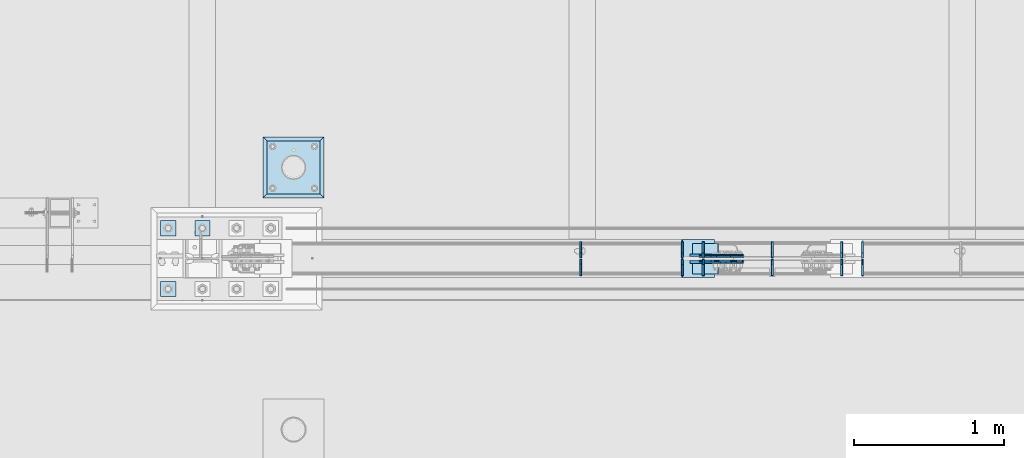
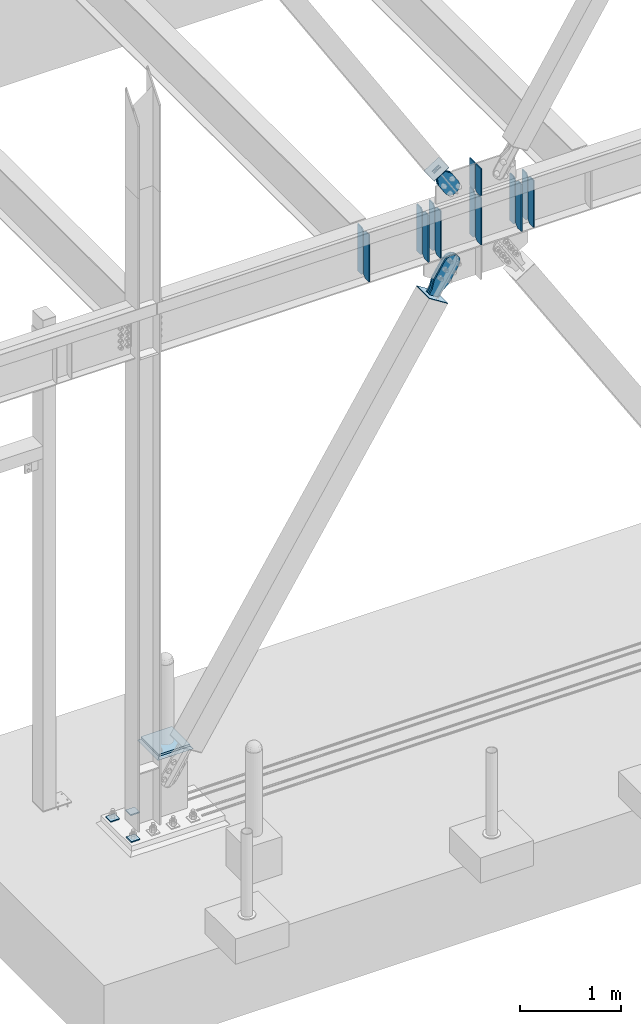
# One storey, part 3383 of 3843: 25 plates, 10 elements without a shape of their own.
"""IFC2X3 building model written with IfcOpenShell, lengths in millimetres."""

from ifc_helpers import new_model, si_unit, frame, origin_with_axes, place, context, subcontext, project, spatial, faceted_brep, material, type_object, element, aggregate, save


model = new_model("IFC2X3")

# Units and contexts
model_context = context("Model", 3, precision=1e-05, world=origin_with_axes())
body_context = subcontext(model_context, "Body", "Model", "MODEL_VIEW")
ifc_project = project(units=[si_unit("LENGTHUNIT", "METRE", prefix="MILLI"), si_unit("AREAUNIT", "SQUARE_METRE"), si_unit("VOLUMEUNIT", "CUBIC_METRE"), si_unit("MASSUNIT", "GRAM", prefix="KILO"), si_unit("TIMEUNIT", "SECOND"), si_unit("PLANEANGLEUNIT", "RADIAN"), si_unit("SOLIDANGLEUNIT", "STERADIAN"), si_unit("THERMODYNAMICTEMPERATUREUNIT", "DEGREE_CELSIUS"), si_unit("LUMINOUSINTENSITYUNIT", "LUMEN")], contexts=[model_context])

# Site, building, storey
site_placement = place(None, origin_with_axes())
site = spatial("IfcSite", under=ifc_project, at=site_placement, CompositionType="ELEMENT")
building_placement = place(site_placement, origin_with_axes())
building = spatial("IfcBuilding", under=site, at=building_placement, Name="Undefined", CompositionType="ELEMENT")
storey_placement = place(building_placement, origin_with_axes())
storey = spatial("IfcBuildingStorey", under=building, at=storey_placement, Name="Undefined", CompositionType="ELEMENT", Elevation=0.0)

# Assembly, plate
assembly_1_placement = place(storey_placement, origin_with_axes())
assembly_1 = element("IfcElementAssembly", 1, at=assembly_1_placement, inside=storey, Name="PIPE_BOLLARD", AssemblyPlace="NOTDEFINED", PredefinedType="RIGID_FRAME")
ifc_material_1 = material(Name="STEEL/A572-50")
plate_type_1 = type_object("IfcPlateType", PredefinedType="NOTDEFINED")
plate_1_placement = place(assembly_1_placement, frame((23291.8, 89547.7, 30518.1), z_axis=(0.0, 1.0, 0.0), x_axis=(1.0, 0.0, 0.0)))
plate_1 = element("IfcPlate", 2, at=plate_1_placement, type_object=plate_type_1, material=ifc_material_1, Name="PLATE", context=body_context, shape_type="Brep", body=[
    faceted_brep([(0.0, -12.6999999999971, 0.0), (0.0, -12.7000000000007, 355.600000000006), (0.0, 12.7000000000007, 355.600000000006), (0.0, 12.6999999999971, 0.0), (355.599999999999, -12.7000000000007, 355.600000000006), (355.599999999999, 12.7000000000007, 355.600000000006), (355.599999999999, -12.7000000000007, 0.0), (355.599999999999, 12.7000000000007, 0.0)], [[[0, 1, 2, 3]], [[1, 4, 5, 2]], [[4, 6, 7, 5]], [[6, 0, 3, 7]], [[5, 7, 3, 2]], [[6, 4, 1, 0]]]),
])
aggregate(assembly_1, [plate_1])

assembly_2_placement = place(storey_placement, origin_with_axes())
assembly_2 = element("IfcElementAssembly", 3, at=assembly_2_placement, inside=storey, Name="GROUT", AssemblyPlace="NOTDEFINED", PredefinedType="REINFORCEMENT_UNIT")
ifc_material_2 = material(Name="CONCRETE/Concrete_Undefined")
plate_type_2 = type_object("IfcPlateType", PredefinedType="NOTDEFINED")
plate_2_placement = place(assembly_2_placement, frame((23266.4, 89522.3, 30492.7), z_axis=(0.0, 1.0, 0.0), x_axis=(1.0, 0.0, 0.0)))
plate_2 = element("IfcPlate", 4, at=plate_2_placement, type_object=plate_type_2, material=ifc_material_2, Name="GROUT", context=body_context, shape_type="Brep", body=[
    faceted_brep([(25.4000000001906, -12.6999999998552, 380.999999999505), (0.0, 12.7000000000007, 406.399999999994), (0.0, 12.6999999999971, 0.0), (25.4000000001906, -12.6999999999898, 25.4000000004453), (380.999999999833, -12.6999999998588, 25.4000000004453), (406.400000000001, 12.7000000000007, 0.0), (406.400000000001, 12.7000000000007, 406.399999999994), (380.999999999833, -12.6999999999898, 380.999999999505)], [[[0, 1, 2, 3]], [[4, 5, 6, 7]], [[4, 7, 0, 3]], [[5, 4, 3, 2]], [[6, 5, 2, 1]], [[7, 6, 1, 0]]]),
])
aggregate(assembly_2, [plate_2])

# Assembly, plates
assembly_3_placement = place(storey_placement, origin_with_axes())
assembly_3 = element("IfcElementAssembly", 5, at=assembly_3_placement, inside=storey, Name="BEAM", AssemblyPlace="NOTDEFINED", PredefinedType="RIGID_FRAME")
plate_type_3 = type_object("IfcPlateType", PredefinedType="NOTDEFINED")
plate_3_placement = place(assembly_3_placement, frame((25388.8874999046, 89110.34375, 35848.925), z_axis=(0.0, 0.0, 1.0), x_axis=(0.0, -1.0, 0.0)))
plate_3 = element("IfcPlate", 6, at=plate_3_placement, type_object=plate_type_3, material=ifc_material_1, Name="PLATE", context=body_context, shape_type="Brep", body=[
    faceted_brep([(0.0, -6.35000000000582, 31.75), (0.0, -6.34999999999854, 539.75), (0.0, 6.34999999999854, 539.75), (0.0, 6.35000000000582, 31.75), (31.75, -6.34999999999854, 571.5), (31.75, 6.34999999999854, 571.5), (108.743750000009, -6.34999999999854, 571.5), (108.743750000009, 6.34999999999854, 571.5), (108.743750000009, -6.34999999999854, 0.0), (108.743750000009, 6.34999999999854, 0.0), (31.75, -6.35000000000582, 0.0), (31.75, 6.35000000000582, 0.0)], [[[0, 1, 2, 3]], [[1, 4, 5, 2]], [[4, 6, 7, 5]], [[6, 8, 9, 7]], [[8, 10, 11, 9]], [[10, 0, 3, 11]], [[5, 7, 9, 11, 3, 2]], [[10, 8, 6, 4, 1, 0]]]),
])
plate_type_4 = type_object("IfcPlateType", PredefinedType="NOTDEFINED")
plate_4_placement = place(assembly_3_placement, frame((25388.8874999046, 89121.45625, 35848.925), z_axis=(0.0, 0.0, 1.0), x_axis=(0.0, 1.0, 0.0)))
plate_4 = element("IfcPlate", 7, at=plate_4_placement, type_object=plate_type_4, material=ifc_material_1, Name="PLATE", context=body_context, shape_type="Brep", body=[
    faceted_brep([(0.0, -6.35000000000582, 31.75), (0.0, -6.34999999999854, 539.75), (0.0, 6.34999999999854, 539.75), (0.0, 6.35000000000582, 31.75), (31.75, -6.34999999999854, 571.5), (31.75, 6.34999999999854, 571.5), (107.950000000012, -6.34999999999854, 571.5), (107.950000000012, 6.34999999999854, 571.5), (107.950000000012, -6.34999999999854, 0.0), (107.950000000012, 6.34999999999854, 0.0), (31.75, -6.35000000000582, 0.0), (31.75, 6.35000000000582, 0.0)], [[[0, 1, 2, 3]], [[1, 4, 5, 2]], [[4, 6, 7, 5]], [[6, 8, 9, 7]], [[8, 10, 11, 9]], [[10, 0, 3, 11]], [[5, 7, 9, 11, 3, 2]], [[10, 8, 6, 4, 1, 0]]]),
])
plate_type_5 = type_object("IfcPlateType", PredefinedType="NOTDEFINED")
plate_5_placement = place(assembly_3_placement, frame((26067.8016625453, 89121.45625, 35848.925), z_axis=(0.0, 1.0, 0.0), x_axis=(0.0, 0.0, 1.0)))
plate_5 = element("IfcPlate", 8, at=plate_5_placement, type_object=plate_type_5, material=ifc_material_1, Name="CB_BEAM", context=body_context, shape_type="Brep", body=[
    faceted_brep([(0.0, -6.34999999999854, 33.3375015258789), (0.0, -6.34999999999854, 108.743749999994), (0.0, 6.34999999999854, 108.743749999994), (0.0, 6.34999999999854, 33.3375015258789), (571.5, -6.34999999999854, 108.743749999994), (571.5, 6.34999999999854, 108.743749999994), (571.5, -6.34999999999854, 33.3375015258789), (571.5, 6.34999999999854, 33.3375015258789), (538.162498474121, -6.34999999999854, 0.0), (538.162498474121, 6.34999999999854, 0.0), (33.3375015258789, -6.34999999999854, 0.0), (33.3375015258789, 6.34999999999854, 0.0)], [[[0, 1, 2, 3]], [[1, 4, 5, 2]], [[4, 6, 7, 5]], [[6, 8, 9, 7]], [[8, 10, 11, 9]], [[10, 0, 3, 11]], [[5, 7, 9, 11, 3, 2]], [[10, 8, 6, 4, 1, 0]]]),
])
plate_6_placement = place(assembly_3_placement, frame((26067.8016625453, 89110.34375, 35848.925), z_axis=(0.0, -1.0, 0.0), x_axis=(0.0, 0.0, 1.0)))
plate_6 = element("IfcPlate", 9, at=plate_6_placement, type_object=plate_type_5, material=ifc_material_1, Name="CB_BEAM", context=body_context, shape_type="Brep", body=[
    faceted_brep([(0.0, -6.34999999999854, 33.3375015258789), (0.0, -6.34999999999854, 108.743749999994), (0.0, 6.34999999999854, 108.743749999994), (0.0, 6.34999999999854, 33.3375015258789), (571.5, -6.34999999999854, 108.743749999994), (571.5, 6.34999999999854, 108.743749999994), (571.5, -6.34999999999854, 33.3375015258789), (571.5, 6.34999999999854, 33.3375015258789), (538.162498474121, -6.34999999999854, 0.0), (538.162498474121, 6.34999999999854, 0.0), (33.3375015258789, -6.34999999999854, 0.0), (33.3375015258789, 6.34999999999854, 0.0)], [[[0, 1, 2, 3]], [[1, 4, 5, 2]], [[4, 6, 7, 5]], [[6, 8, 9, 7]], [[8, 10, 11, 9]], [[10, 0, 3, 11]], [[5, 7, 9, 11, 3, 2]], [[10, 8, 6, 4, 1, 0]]]),
])
plate_7_placement = place(assembly_3_placement, frame((26207.1319682996, 89121.45625, 35848.9250050158), z_axis=(0.0, 1.0, 0.0), x_axis=(0.0, 0.0, 1.0)))
plate_7 = element("IfcPlate", 10, at=plate_7_placement, type_object=plate_type_5, material=ifc_material_1, Name="CB_BEAM", context=body_context, shape_type="Brep", body=[
    faceted_brep([(0.0, -6.34999999999854, 33.3375015258789), (0.0, -6.34999999999854, 108.743749999994), (0.0, 6.34999999999854, 108.743749999994), (0.0, 6.34999999999854, 33.3375015258789), (571.5, -6.34999999999854, 108.743749999994), (571.5, 6.34999999999854, 108.743749999994), (571.5, -6.34999999999854, 33.3375015258789), (571.5, 6.34999999999854, 33.3375015258789), (538.162498474121, -6.34999999999854, 0.0), (538.162498474121, 6.34999999999854, 0.0), (33.3375015258789, -6.34999999999854, 0.0), (33.3375015258789, 6.34999999999854, 0.0)], [[[0, 1, 2, 3]], [[1, 4, 5, 2]], [[4, 6, 7, 5]], [[6, 8, 9, 7]], [[8, 10, 11, 9]], [[10, 0, 3, 11]], [[5, 7, 9, 11, 3, 2]], [[10, 8, 6, 4, 1, 0]]]),
])
plate_8_placement = place(assembly_3_placement, frame((26207.1319682996, 89110.34375, 35848.9250050158), z_axis=(0.0, -1.0, 0.0), x_axis=(0.0, 0.0, 1.0)))
plate_8 = element("IfcPlate", 11, at=plate_8_placement, type_object=plate_type_5, material=ifc_material_1, Name="CB_BEAM", context=body_context, shape_type="Brep", body=[
    faceted_brep([(0.0, -6.34999999999854, 33.3375015258789), (0.0, -6.34999999999854, 108.743749999994), (0.0, 6.34999999999854, 108.743749999994), (0.0, 6.34999999999854, 33.3375015258789), (571.5, -6.34999999999854, 108.743749999994), (571.5, 6.34999999999854, 108.743749999994), (571.5, -6.34999999999854, 33.3375015258789), (571.5, 6.34999999999854, 33.3375015258789), (538.162498474121, -6.34999999999854, 0.0), (538.162498474121, 6.34999999999854, 0.0), (33.3375015258789, -6.34999999999854, 0.0), (33.3375015258789, 6.34999999999854, 0.0)], [[[0, 1, 2, 3]], [[1, 4, 5, 2]], [[4, 6, 7, 5]], [[6, 8, 9, 7]], [[8, 10, 11, 9]], [[10, 0, 3, 11]], [[5, 7, 9, 11, 3, 2]], [[10, 8, 6, 4, 1, 0]]]),
])
plate_9_placement = place(assembly_3_placement, frame((27272.1976786645, 89121.45625, 35848.9250050158), z_axis=(0.0, 1.0, 0.0), x_axis=(0.0, 0.0, 1.0)))
plate_9 = element("IfcPlate", 12, at=plate_9_placement, type_object=plate_type_5, material=ifc_material_1, Name="CB_BEAM", context=body_context, shape_type="Brep", body=[
    faceted_brep([(0.0, -6.34999999999854, 33.3375015258789), (0.0, -6.34999999999854, 108.743749999994), (0.0, 6.34999999999854, 108.743749999994), (0.0, 6.34999999999854, 33.3375015258789), (571.5, -6.34999999999854, 108.743749999994), (571.5, 6.34999999999854, 108.743749999994), (571.5, -6.34999999999854, 33.3375015258789), (571.5, 6.34999999999854, 33.3375015258789), (538.162498474121, -6.34999999999854, 0.0), (538.162498474121, 6.34999999999854, 0.0), (33.3375015258789, -6.34999999999854, 0.0), (33.3375015258789, 6.34999999999854, 0.0)], [[[0, 1, 2, 3]], [[1, 4, 5, 2]], [[4, 6, 7, 5]], [[6, 8, 9, 7]], [[8, 10, 11, 9]], [[10, 0, 3, 11]], [[5, 7, 9, 11, 3, 2]], [[10, 8, 6, 4, 1, 0]]]),
])
plate_10_placement = place(assembly_3_placement, frame((27272.1976786645, 89110.34375, 35848.9250050158), z_axis=(0.0, -1.0, 0.0), x_axis=(0.0, 0.0, 1.0)))
plate_10 = element("IfcPlate", 13, at=plate_10_placement, type_object=plate_type_5, material=ifc_material_1, Name="CB_BEAM", context=body_context, shape_type="Brep", body=[
    faceted_brep([(0.0, -6.34999999999854, 33.3375015258789), (0.0, -6.34999999999854, 108.743749999994), (0.0, 6.34999999999854, 108.743749999994), (0.0, 6.34999999999854, 33.3375015258789), (571.5, -6.34999999999854, 108.743749999994), (571.5, 6.34999999999854, 108.743749999994), (571.5, -6.34999999999854, 33.3375015258789), (571.5, 6.34999999999854, 33.3375015258789), (538.162498474121, -6.34999999999854, 0.0), (538.162498474121, 6.34999999999854, 0.0), (33.3375015258789, -6.34999999999854, 0.0), (33.3375015258789, 6.34999999999854, 0.0)], [[[0, 1, 2, 3]], [[1, 4, 5, 2]], [[4, 6, 7, 5]], [[6, 8, 9, 7]], [[8, 10, 11, 9]], [[10, 0, 3, 11]], [[5, 7, 9, 11, 3, 2]], [[10, 8, 6, 4, 1, 0]]]),
])
plate_11_placement = place(assembly_3_placement, frame((27132.8677160584, 89121.45625, 35848.925), z_axis=(0.0, 1.0, 0.0), x_axis=(0.0, 0.0, 1.0)))
plate_11 = element("IfcPlate", 14, at=plate_11_placement, type_object=plate_type_5, material=ifc_material_1, Name="CB_BEAM", context=body_context, shape_type="Brep", body=[
    faceted_brep([(0.0, -6.34999999999854, 33.3375015258789), (0.0, -6.34999999999854, 108.743749999994), (0.0, 6.34999999999854, 108.743749999994), (0.0, 6.34999999999854, 33.3375015258789), (571.5, -6.34999999999854, 108.743749999994), (571.5, 6.34999999999854, 108.743749999994), (571.5, -6.34999999999854, 33.3375015258789), (571.5, 6.34999999999854, 33.3375015258789), (538.162498474121, -6.34999999999854, 0.0), (538.162498474121, 6.34999999999854, 0.0), (33.3375015258789, -6.34999999999854, 0.0), (33.3375015258789, 6.34999999999854, 0.0)], [[[0, 1, 2, 3]], [[1, 4, 5, 2]], [[4, 6, 7, 5]], [[6, 8, 9, 7]], [[8, 10, 11, 9]], [[10, 0, 3, 11]], [[5, 7, 9, 11, 3, 2]], [[10, 8, 6, 4, 1, 0]]]),
])
plate_12_placement = place(assembly_3_placement, frame((27132.8677160584, 89110.34375, 35848.925), z_axis=(0.0, -1.0, 0.0), x_axis=(0.0, 0.0, 1.0)))
plate_12 = element("IfcPlate", 15, at=plate_12_placement, type_object=plate_type_5, material=ifc_material_1, Name="CB_BEAM", context=body_context, shape_type="Brep", body=[
    faceted_brep([(0.0, -6.34999999999854, 33.3375015258789), (0.0, -6.34999999999854, 108.743749999994), (0.0, 6.34999999999854, 108.743749999994), (0.0, 6.34999999999854, 33.3375015258789), (571.5, -6.34999999999854, 108.743749999994), (571.5, 6.34999999999854, 108.743749999994), (571.5, -6.34999999999854, 33.3375015258789), (571.5, 6.34999999999854, 33.3375015258789), (538.162498474121, -6.34999999999854, 0.0), (538.162498474121, 6.34999999999854, 0.0), (33.3375015258789, -6.34999999999854, 0.0), (33.3375015258789, 6.34999999999854, 0.0)], [[[0, 1, 2, 3]], [[1, 4, 5, 2]], [[4, 6, 7, 5]], [[6, 8, 9, 7]], [[8, 10, 11, 9]], [[10, 0, 3, 11]], [[5, 7, 9, 11, 3, 2]], [[10, 8, 6, 4, 1, 0]]]),
])
plate_13_placement = place(assembly_3_placement, frame((26670.0000031996, 89121.45625, 35848.925), z_axis=(0.0, 1.0, 0.0), x_axis=(0.0, 0.0, 1.0)))
plate_13 = element("IfcPlate", 16, at=plate_13_placement, type_object=plate_type_5, material=ifc_material_1, Name="CB_BEAM", context=body_context, shape_type="Brep", body=[
    faceted_brep([(0.0, -6.34999999999854, 33.3375015258789), (0.0, -6.34999999999854, 108.743749999994), (0.0, 6.34999999999854, 108.743749999994), (0.0, 6.34999999999854, 33.3375015258789), (571.5, -6.34999999999854, 108.743749999994), (571.5, 6.34999999999854, 108.743749999994), (571.5, -6.34999999999854, 33.3375015258789), (571.5, 6.34999999999854, 33.3375015258789), (538.162498474121, -6.34999999999854, 0.0), (538.162498474121, 6.34999999999854, 0.0), (33.3375015258789, -6.34999999999854, 0.0), (33.3375015258789, 6.34999999999854, 0.0)], [[[0, 1, 2, 3]], [[1, 4, 5, 2]], [[4, 6, 7, 5]], [[6, 8, 9, 7]], [[8, 10, 11, 9]], [[10, 0, 3, 11]], [[5, 7, 9, 11, 3, 2]], [[10, 8, 6, 4, 1, 0]]]),
])
plate_14_placement = place(assembly_3_placement, frame((26670.0000031996, 89110.34375, 35848.925), z_axis=(0.0, -1.0, 0.0), x_axis=(0.0, 0.0, 1.0)))
plate_14 = element("IfcPlate", 17, at=plate_14_placement, type_object=plate_type_5, material=ifc_material_1, Name="CB_BEAM", context=body_context, shape_type="Brep", body=[
    faceted_brep([(0.0, -6.34999999999854, 33.3375015258789), (0.0, -6.34999999999854, 108.743749999994), (0.0, 6.34999999999854, 108.743749999994), (0.0, 6.34999999999854, 33.3375015258789), (571.5, -6.34999999999854, 108.743749999994), (571.5, 6.34999999999854, 108.743749999994), (571.5, -6.34999999999854, 33.3375015258789), (571.5, 6.34999999999854, 33.3375015258789), (538.162498474121, -6.34999999999854, 0.0), (538.162498474121, 6.34999999999854, 0.0), (33.3375015258789, -6.34999999999854, 0.0), (33.3375015258789, 6.34999999999854, 0.0)], [[[0, 1, 2, 3]], [[1, 4, 5, 2]], [[4, 6, 7, 5]], [[6, 8, 9, 7]], [[8, 10, 11, 9]], [[10, 0, 3, 11]], [[5, 7, 9, 11, 3, 2]], [[10, 8, 6, 4, 1, 0]]]),
])
plate_type_6 = type_object("IfcPlateType", PredefinedType="NOTDEFINED")
plate_15_placement = place(assembly_3_placement, frame((26670.0000031996, 89125.425, 36436.3), z_axis=(0.0, 1.0, 0.0), x_axis=(0.0, 0.0, 1.0)))
plate_15 = element("IfcPlate", 18, at=plate_15_placement, type_object=plate_type_6, material=ifc_material_1, Name="CB", context=body_context, shape_type="Brep", body=[
    faceted_brep([(0.0, -6.34999999999854, 19.0499992370605), (0.0, -6.34999999999854, 104.775000000009), (0.0, 6.34999999999854, 104.775000000009), (0.0, 6.34999999999854, 19.0499992370605), (333.366558250316, -6.34999999999854, 104.775000000009), (333.366558250316, 6.34999999999854, 104.775000000009), (333.366558250316, -6.34999999999854, 0.0), (333.366558250316, 6.34999999999854, 0.0), (19.0499992370605, -6.34999999999854, 0.0), (19.0499992370605, 6.34999999999854, 0.0)], [[[0, 1, 2, 3]], [[1, 4, 5, 2]], [[4, 6, 7, 5]], [[6, 8, 9, 7]], [[8, 0, 3, 9]], [[5, 7, 9, 3, 2]], [[8, 6, 4, 1, 0]]]),
])
plate_16_placement = place(assembly_3_placement, frame((26670.0000031996, 89106.375, 36436.3), z_axis=(0.0, -1.0, 0.0), x_axis=(0.0, 0.0, 1.0)))
plate_16 = element("IfcPlate", 19, at=plate_16_placement, type_object=plate_type_6, material=ifc_material_1, Name="CB", context=body_context, shape_type="Brep", body=[
    faceted_brep([(0.0, -6.34999999999854, 19.0499992370605), (0.0, -6.34999999999854, 104.775000000009), (0.0, 6.34999999999854, 104.775000000009), (0.0, 6.34999999999854, 19.0499992370605), (333.366558250316, -6.34999999999854, 104.775000000009), (333.366558250316, 6.34999999999854, 104.775000000009), (333.366558250316, -6.34999999999854, 0.0), (333.366558250316, 6.34999999999854, 0.0), (19.0499992370605, -6.34999999999854, 0.0), (19.0499992370605, 6.34999999999854, 0.0)], [[[0, 1, 2, 3]], [[1, 4, 5, 2]], [[4, 6, 7, 5]], [[6, 8, 9, 7]], [[8, 0, 3, 9]], [[5, 7, 9, 3, 2]], [[8, 6, 4, 1, 0]]]),
])
aggregate(assembly_3, [plate_3, plate_4, plate_5, plate_6, plate_7, plate_8, plate_9, plate_10, plate_11, plate_12, plate_13, plate_14, plate_15, plate_16])

# Assembly, plate
assembly_4_placement = place(storey_placement, origin_with_axes())
assembly_4 = element("IfcElementAssembly", 20, at=assembly_4_placement, inside=storey, AssemblyPlace="NOTDEFINED", PredefinedType="RIGID_FRAME")
ifc_material_3 = material(Name="STEEL/A36")
plate_type_7 = type_object("IfcPlateType", PredefinedType="NOTDEFINED")
plate_17_placement = place(assembly_4_placement, frame((26259.8051989802, 89131.7750061035, 36877.9619396575), z_axis=(-0.848184242014813, 0.0, -0.529701323009256), x_axis=(0.529701323009257, 0.0, -0.848184242014813)))
plate_17 = element("IfcPlate", 21, at=plate_17_placement, type_object=plate_type_7, material=ifc_material_3, context=body_context, shape_type="Brep", body=[
    faceted_brep([(0.0, -6.3499999046162, 0.0), (2.18278728425503e-10, -6.35000000000582, 91.5986124321353), (2.18278728425503e-10, 6.35000000000582, 91.5986124321353), (7.27595761418343e-12, 6.3499999046162, 0.0), (69.8499999987471, -6.35000000000582, 91.598612432037), (69.8499999987471, 6.35000000000582, 91.598612432037), (171.44999999673, -6.35000000000582, 136.286806214401), (171.44999999673, 6.35000000000582, 136.286806214401), (316.534985839971, -6.35000000000582, 136.286806214212), (316.534985839971, 6.35000000000582, 136.286806214212), (351.163054093879, -6.35000000000582, 129.398855179952), (351.163054093879, 6.35000000000582, 129.398855179952), (380.51931286032, -6.35000000000582, 109.783630182814), (380.51931286032, 6.35000000000582, 109.783630182814), (400.134537857251, -6.35000000000582, 80.42737141615), (400.134537857251, 6.35000000000582, 80.42737141615), (407.022488891344, -6.35000000000582, 45.7993092690485), (407.022488891344, 6.35000000000582, 45.7993092690485), (400.134537857084, -6.35000000000582, 11.1712410149557), (400.134537857084, 6.35000000000582, 11.1712410149557), (380.519312860015, -6.35000000000582, -18.1850177516608), (380.519312860015, 6.35000000000582, -18.1850177516608), (351.163054093486, -6.35000000000582, -37.8002427487263), (351.163054093486, 6.35000000000582, -37.8002427487263), (316.534988893036, -6.35000000000582, -44.6881937828948), (316.534988893036, 6.35000000000582, -44.6881937828948), (171.449999996279, -6.35000000000582, -44.6881937827056), (171.449999996279, 6.35000000000582, -44.6881937827056), (69.8499999985434, -6.35000000000582, -8.73114913702011e-11), (69.8499999985434, 6.35000000000582, -8.73114913702011e-11)], [[[0, 1, 2, 3]], [[1, 4, 5, 2]], [[4, 6, 7, 5]], [[6, 8, 9, 7]], [[8, 10, 11, 9]], [[10, 12, 13, 11]], [[12, 14, 15, 13]], [[14, 16, 17, 15]], [[16, 18, 19, 17]], [[18, 20, 21, 19]], [[20, 22, 23, 21]], [[22, 24, 25, 23]], [[24, 26, 27, 25]], [[26, 28, 29, 27]], [[28, 0, 3, 29]], [[5, 7, 9, 11, 13, 15, 17, 19, 21, 23, 25, 27, 29, 3, 2]], [[28, 26, 24, 22, 20, 18, 16, 14, 12, 10, 8, 6, 4, 1, 0]]]),
])
aggregate(assembly_4, [plate_17])

assembly_5_placement = place(storey_placement, origin_with_axes())
assembly_5 = element("IfcElementAssembly", 22, at=assembly_5_placement, inside=storey, AssemblyPlace="NOTDEFINED", PredefinedType="RIGID_FRAME")
plate_18_placement = place(assembly_5_placement, frame((26259.8051989802, 89100.0250061035, 36877.9619396575), z_axis=(-0.848184242014813, 0.0, -0.529701323009256), x_axis=(0.529701323009257, 0.0, -0.848184242014813)))
plate_18 = element("IfcPlate", 23, at=plate_18_placement, type_object=plate_type_7, material=ifc_material_3, context=body_context, shape_type="Brep", body=[
    faceted_brep([(0.0, -6.3499999046162, 0.0), (2.18278728425503e-10, -6.35000000000582, 91.5986124321353), (2.18278728425503e-10, 6.35000000000582, 91.5986124321353), (7.27595761418343e-12, 6.3499999046162, 0.0), (69.8499999987471, -6.35000000000582, 91.598612432037), (69.8499999987471, 6.35000000000582, 91.598612432037), (171.44999999673, -6.35000000000582, 136.286806214401), (171.44999999673, 6.35000000000582, 136.286806214401), (316.534985839971, -6.35000000000582, 136.286806214212), (316.534985839971, 6.35000000000582, 136.286806214212), (351.163054093879, -6.35000000000582, 129.398855179952), (351.163054093879, 6.35000000000582, 129.398855179952), (380.51931286032, -6.35000000000582, 109.783630182814), (380.51931286032, 6.35000000000582, 109.783630182814), (400.134537857251, -6.35000000000582, 80.42737141615), (400.134537857251, 6.35000000000582, 80.42737141615), (407.022488891344, -6.35000000000582, 45.7993092690485), (407.022488891344, 6.35000000000582, 45.7993092690485), (400.134537857084, -6.35000000000582, 11.1712410149557), (400.134537857084, 6.35000000000582, 11.1712410149557), (380.519312860015, -6.35000000000582, -18.1850177516608), (380.519312860015, 6.35000000000582, -18.1850177516608), (351.163054093486, -6.35000000000582, -37.8002427487263), (351.163054093486, 6.35000000000582, -37.8002427487263), (316.534988893036, -6.35000000000582, -44.6881937828948), (316.534988893036, 6.35000000000582, -44.6881937828948), (171.449999996279, -6.35000000000582, -44.6881937827056), (171.449999996279, 6.35000000000582, -44.6881937827056), (69.8499999985434, -6.35000000000582, -8.73114913702011e-11), (69.8499999985434, 6.35000000000582, -8.73114913702011e-11)], [[[0, 1, 2, 3]], [[1, 4, 5, 2]], [[4, 6, 7, 5]], [[6, 8, 9, 7]], [[8, 10, 11, 9]], [[10, 12, 13, 11]], [[12, 14, 15, 13]], [[14, 16, 17, 15]], [[16, 18, 19, 17]], [[18, 20, 21, 19]], [[20, 22, 23, 21]], [[22, 24, 25, 23]], [[24, 26, 27, 25]], [[26, 28, 29, 27]], [[28, 0, 3, 29]], [[5, 7, 9, 11, 13, 15, 17, 19, 21, 23, 25, 27, 29, 3, 2]], [[28, 26, 24, 22, 20, 18, 16, 14, 12, 10, 8, 6, 4, 1, 0]]]),
])
aggregate(assembly_5, [plate_18])

assembly_6_placement = place(storey_placement, origin_with_axes())
assembly_6 = element("IfcElementAssembly", 24, at=assembly_6_placement, inside=storey, Name="Plate", AssemblyPlace="NOTDEFINED", PredefinedType="RIGID_FRAME")
plate_type_8 = type_object("IfcPlateType", PredefinedType="NOTDEFINED")
plate_19_placement = place(assembly_6_placement, frame((26136.4652321464, 89217.5000061035, 36797.1913473516), z_axis=(0.848184242014813, 0.0, 0.529701323009256), x_axis=(0.0, -1.0, 0.0)))
plate_19 = element("IfcPlate", 25, at=plate_19_placement, type_object=plate_type_8, material=ifc_material_3, Name="Plate", context=body_context, shape_type="Brep", body=[
    faceted_brep([(0.0, -3.17499999999927, 0.0), (0.0, -3.17500000043947, 203.200000001736), (0.0, 3.1749999995518, 203.200000001743), (0.0, 3.17499999999927, 0.0), (203.200000000012, -3.17500000043947, 203.200000001736), (203.200000000012, 3.1749999995518, 203.200000001743), (203.199996948242, -3.17499999999927, 0.0), (203.199996948242, 3.17499999999927, 0.0)], [[[0, 1, 2, 3]], [[1, 4, 5, 2]], [[4, 6, 7, 5]], [[6, 0, 3, 7]], [[5, 7, 3, 2]], [[6, 4, 1, 0]]]),
])
aggregate(assembly_6, [plate_19])

# Assembly, plates
assembly_7_placement = place(storey_placement, origin_with_axes())
assembly_7 = element("IfcElementAssembly", 26, at=assembly_7_placement, inside=storey, Name="TEMPLATE", AssemblyPlace="NOTDEFINED", PredefinedType="RIGID_FRAME")
plate_type_9 = type_object("IfcPlateType", PredefinedType="NOTDEFINED")
plate_20_placement = place(assembly_7_placement, frame((22809.2, 89369.9, 30130.75), z_axis=(0.0, -1.0, 0.0), x_axis=(1.0, 0.0, 0.0)))
plate_20 = element("IfcPlate", 27, at=plate_20_placement, type_object=plate_type_9, material=ifc_material_1, Name="Washer Plate", context=body_context, shape_type="Brep", body=[
    faceted_brep([(0.0, -6.3499999046162, 0.0), (-1.67347025126219e-10, -6.35000000000582, 101.600000000151), (-1.67347025126219e-10, 6.35000000000582, 101.600000000151), (7.27595761418343e-12, 6.3499999046162, 0.0), (101.599998474121, -6.34999999999854, 101.599998474121), (101.599998474121, 6.34999999999854, 101.599998474121), (101.6, -6.34999999999854, 0.0), (101.6, 6.34999999999854, 0.0)], [[[0, 1, 2, 3]], [[1, 4, 5, 2]], [[4, 6, 7, 5]], [[6, 0, 3, 7]], [[5, 7, 3, 2]], [[6, 4, 1, 0]]]),
])
plate_21_placement = place(assembly_7_placement, frame((22580.6, 88963.5, 30130.75), z_axis=(0.0, -1.0, 0.0), x_axis=(1.0, 0.0, 0.0)))
plate_21 = element("IfcPlate", 28, at=plate_21_placement, type_object=plate_type_9, material=ifc_material_1, Name="Washer Plate", context=body_context, shape_type="Brep", body=[
    faceted_brep([(0.0, -6.3499999046162, 0.0), (-1.67347025126219e-10, -6.35000000000582, 101.600000000151), (-1.67347025126219e-10, 6.35000000000582, 101.600000000151), (7.27595761418343e-12, 6.3499999046162, 0.0), (101.599998474121, -6.34999999999854, 101.599998474121), (101.599998474121, 6.34999999999854, 101.599998474121), (101.6, -6.34999999999854, 0.0), (101.6, 6.34999999999854, 0.0)], [[[0, 1, 2, 3]], [[1, 4, 5, 2]], [[4, 6, 7, 5]], [[6, 0, 3, 7]], [[5, 7, 3, 2]], [[6, 4, 1, 0]]]),
])
plate_22_placement = place(assembly_7_placement, frame((22580.6, 89369.9, 30130.75), z_axis=(0.0, -1.0, 0.0), x_axis=(1.0, 0.0, 0.0)))
plate_22 = element("IfcPlate", 29, at=plate_22_placement, type_object=plate_type_9, material=ifc_material_1, Name="Washer Plate", context=body_context, shape_type="Brep", body=[
    faceted_brep([(0.0, -6.3499999046162, 0.0), (-1.67347025126219e-10, -6.35000000000582, 101.600000000151), (-1.67347025126219e-10, 6.35000000000582, 101.600000000151), (7.27595761418343e-12, 6.3499999046162, 0.0), (101.599998474121, -6.34999999999854, 101.599998474121), (101.599998474121, 6.34999999999854, 101.599998474121), (101.6, -6.34999999999854, 0.0), (101.6, 6.34999999999854, 0.0)], [[[0, 1, 2, 3]], [[1, 4, 5, 2]], [[4, 6, 7, 5]], [[6, 0, 3, 7]], [[5, 7, 3, 2]], [[6, 4, 1, 0]]]),
])
aggregate(assembly_7, [plate_20, plate_21, plate_22])

# Assembly, plate
assembly_8_placement = place(storey_placement, origin_with_axes())
assembly_8 = element("IfcElementAssembly", 30, at=assembly_8_placement, inside=storey, AssemblyPlace="NOTDEFINED", PredefinedType="RIGID_FRAME")
plate_type_10 = type_object("IfcPlateType", PredefinedType="NOTDEFINED")
plate_23_placement = place(assembly_8_placement, frame((26225.0528930668, 89138.1250061035, 35314.1438248237), z_axis=(-0.844597156660866, 0.0, 0.535402318785024), x_axis=(0.535402318785024, 0.0, 0.844597156660866)))
plate_23 = element("IfcPlate", 31, at=plate_23_placement, type_object=plate_type_10, material=ifc_material_3, context=body_context, shape_type="Brep", body=[
    faceted_brep([(0.0, -9.52500000000146, 0.0), (-1.04046193882823e-09, -9.52499999999418, 127.02645557576), (-1.04046193882823e-09, 9.52499999999418, 127.02645557576), (0.0, 9.52500000000146, 0.0), (69.8499999968899, -9.52499999999418, 127.026455575353), (69.8499999968899, 9.52499999999418, 127.026455575353), (171.449999994144, -9.52499999999418, 160.350727789177), (171.449999994144, 9.52499999999418, 160.350727789177), (390.129297651329, -9.52499999999418, 160.350727787925), (390.129297651329, 9.52499999999418, 160.350727787925), (427.187405116643, -9.52499999999418, 152.979411901222), (427.187405116643, 9.52499999999418, 152.979411901222), (458.603751652932, -9.52499999999418, 131.987680264123), (458.603751652932, 9.52499999999418, 131.987680264123), (479.595483290015, -9.52499999999418, 100.571333727821), (479.595483290015, 9.52499999999418, 100.571333727821), (486.966799176706, -9.52499999999418, 63.5132293100978), (486.966799176706, 9.52499999999418, 63.5132293100978), (479.595483290208, -9.52499999999418, 26.4551218441993), (479.595483290208, 9.52499999999418, 26.4551218441993), (458.603751652907, -9.52499999999418, -4.96122469259717), (458.603751652907, 9.52499999999418, -4.96122469259717), (427.187405116098, -9.52499999999418, -25.9529563298856), (427.187405116098, 9.52499999999418, -25.9529563298856), (390.129299180044, -9.52499999999418, -33.3242722163704), (390.129299180044, 9.52499999999418, -33.3242722163704), (171.449999995208, -9.52499999999418, -33.3242722151044), (171.449999995208, 9.52499999999418, -33.3242722151044), (69.8499999979995, -9.52499999999418, -4.00177668780088e-10), (69.8499999979995, 9.52499999999418, -4.00177668780088e-10)], [[[0, 1, 2, 3]], [[1, 4, 5, 2]], [[4, 6, 7, 5]], [[6, 8, 9, 7]], [[8, 10, 11, 9]], [[10, 12, 13, 11]], [[12, 14, 15, 13]], [[14, 16, 17, 15]], [[16, 18, 19, 17]], [[18, 20, 21, 19]], [[20, 22, 23, 21]], [[22, 24, 25, 23]], [[24, 26, 27, 25]], [[26, 28, 29, 27]], [[28, 0, 3, 29]], [[5, 7, 9, 11, 13, 15, 17, 19, 21, 23, 25, 27, 29, 3, 2]], [[28, 26, 24, 22, 20, 18, 16, 14, 12, 10, 8, 6, 4, 1, 0]]]),
])
aggregate(assembly_8, [plate_23])

assembly_9_placement = place(storey_placement, origin_with_axes())
assembly_9 = element("IfcElementAssembly", 32, at=assembly_9_placement, inside=storey, AssemblyPlace="NOTDEFINED", PredefinedType="RIGID_FRAME")
plate_24_placement = place(assembly_9_placement, frame((26225.0528930668, 89093.6750061035, 35314.1438248237), z_axis=(-0.844597156660866, 0.0, 0.535402318785024), x_axis=(0.535402318785024, 0.0, 0.844597156660866)))
plate_24 = element("IfcPlate", 33, at=plate_24_placement, type_object=plate_type_10, material=ifc_material_3, context=body_context, shape_type="Brep", body=[
    faceted_brep([(0.0, -9.52500000000146, 0.0), (-1.04046193882823e-09, -9.52499999999418, 127.02645557576), (-1.04046193882823e-09, 9.52499999999418, 127.02645557576), (0.0, 9.52500000000146, 0.0), (69.8499999968899, -9.52499999999418, 127.026455575353), (69.8499999968899, 9.52499999999418, 127.026455575353), (171.449999994144, -9.52499999999418, 160.350727789177), (171.449999994144, 9.52499999999418, 160.350727789177), (390.129297651329, -9.52499999999418, 160.350727787925), (390.129297651329, 9.52499999999418, 160.350727787925), (427.187405116643, -9.52499999999418, 152.979411901222), (427.187405116643, 9.52499999999418, 152.979411901222), (458.603751652932, -9.52499999999418, 131.987680264123), (458.603751652932, 9.52499999999418, 131.987680264123), (479.595483290015, -9.52499999999418, 100.571333727821), (479.595483290015, 9.52499999999418, 100.571333727821), (486.966799176706, -9.52499999999418, 63.5132293100978), (486.966799176706, 9.52499999999418, 63.5132293100978), (479.595483290208, -9.52499999999418, 26.4551218441993), (479.595483290208, 9.52499999999418, 26.4551218441993), (458.603751652907, -9.52499999999418, -4.96122469259717), (458.603751652907, 9.52499999999418, -4.96122469259717), (427.187405116098, -9.52499999999418, -25.9529563298856), (427.187405116098, 9.52499999999418, -25.9529563298856), (390.129299180044, -9.52499999999418, -33.3242722163704), (390.129299180044, 9.52499999999418, -33.3242722163704), (171.449999995208, -9.52499999999418, -33.3242722151044), (171.449999995208, 9.52499999999418, -33.3242722151044), (69.8499999979995, -9.52499999999418, -4.00177668780088e-10), (69.8499999979995, 9.52499999999418, -4.00177668780088e-10)], [[[0, 1, 2, 3]], [[1, 4, 5, 2]], [[4, 6, 7, 5]], [[6, 8, 9, 7]], [[8, 10, 11, 9]], [[10, 12, 13, 11]], [[12, 14, 15, 13]], [[14, 16, 17, 15]], [[16, 18, 19, 17]], [[18, 20, 21, 19]], [[20, 22, 23, 21]], [[22, 24, 25, 23]], [[24, 26, 27, 25]], [[26, 28, 29, 27]], [[28, 0, 3, 29]], [[5, 7, 9, 11, 13, 15, 17, 19, 21, 23, 25, 27, 29, 3, 2]], [[28, 26, 24, 22, 20, 18, 16, 14, 12, 10, 8, 6, 4, 1, 0]]]),
])
aggregate(assembly_9, [plate_24])

assembly_10_placement = place(storey_placement, origin_with_axes())
assembly_10 = element("IfcElementAssembly", 34, at=assembly_10_placement, inside=storey, Name="Plate", AssemblyPlace="NOTDEFINED", PredefinedType="RIGID_FRAME")
plate_type_11 = type_object("IfcPlateType", PredefinedType="NOTDEFINED")
plate_25_placement = place(assembly_10_placement, frame((26280.3735426532, 88988.9000061035, 35282.834455773), z_axis=(-0.844597156660866, 0.0, 0.535402318785024), x_axis=(0.0, 1.0, 0.0)))
plate_25 = element("IfcPlate", 35, at=plate_25_placement, type_object=plate_type_11, material=ifc_material_3, Name="Plate", context=body_context, shape_type="Brep", body=[
    faceted_brep([(0.0, -3.17499999999927, 0.0), (0.0, -3.17499999965185, 254.000000005151), (0.0, 3.17500000035216, 254.000000005166), (0.0, 3.17499999999927, 0.0), (254.0, -3.17499999965185, 254.000000005151), (254.0, 3.17500000035216, 254.000000005166), (254.0, -3.17500000000291, 0.0), (254.0, 3.17499999999927, 1.45519152283669e-11)], [[[0, 1, 2, 3]], [[1, 4, 5, 2]], [[4, 6, 7, 5]], [[6, 0, 3, 7]], [[5, 7, 3, 2]], [[6, 4, 1, 0]]]),
])
aggregate(assembly_10, [plate_25])

save(model, "model.ifc")
